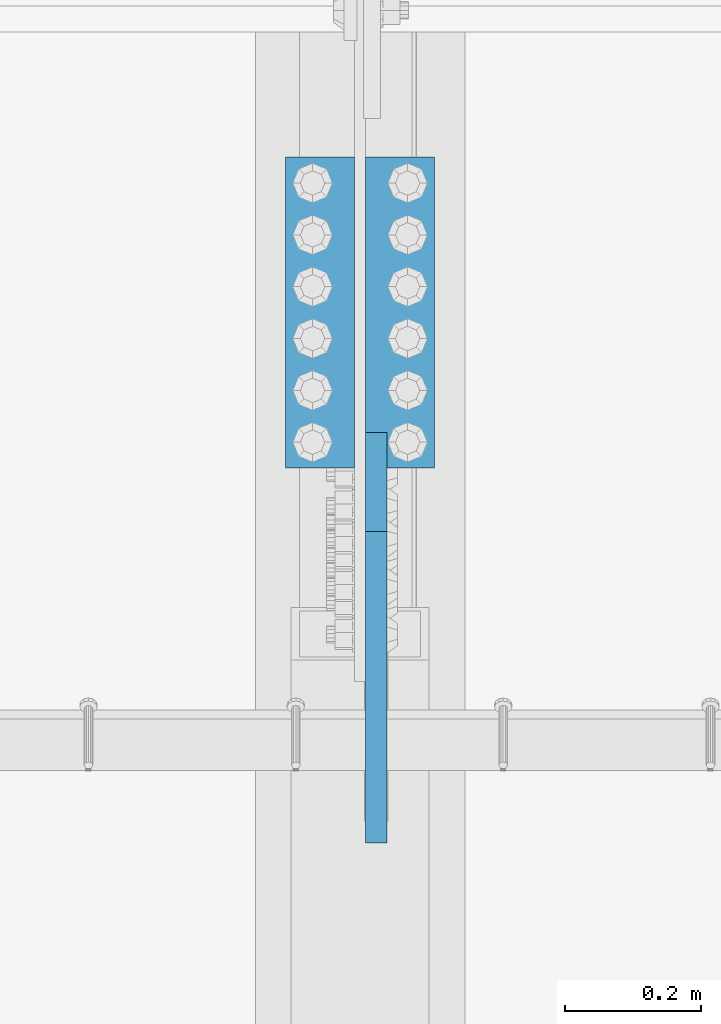
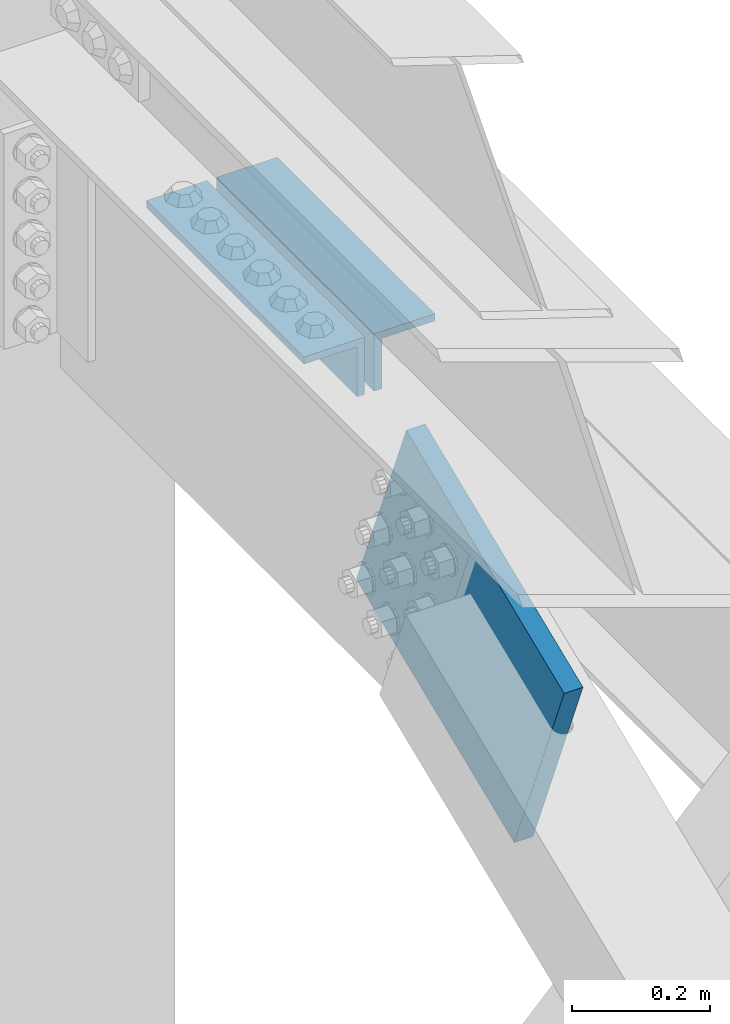
# One storey, part 2512 of 3843: 2 beams, 1 member, 2 elements without a shape of their own.
"""IFC2X3 building model written with IfcOpenShell, lengths in millimetres."""

import ifcopenshell
import ifcopenshell.guid

model = None  # the IFC model being written
_history = None  # IfcOwnerHistory: only IFC2X3 demands one
_inside = {}  # id of a spatial element -> (the spatial element, [elements in it])
_under = {}  # id of a project, library or spatial element -> (it, [spatial elements below it])
_declared = {}  # id of a project -> (the project, [libraries it declares])
_typed = {}  # id of a type object -> (the type object, [elements of that type])
_made_of = {}  # id of a material, layer set ... -> (it, [elements and type objects made of it])


def new_model(schema):
    """Start an empty IFC model of exactly this schema.

    Asked for "IFC4X3", IfcOpenShell would pick the latest addendum, in which some entities
    have other attributes; the version numbers below select the first issue.
    IFC2X3 requires an IfcOwnerHistory on every rooted entity: one is made here for all.
    """
    global model, _history
    if schema == "IFC4X3":
        model = ifcopenshell.file(schema_version=(4, 3, 0, 0))
    else:
        model = ifcopenshell.file(schema=schema)
    _inside.clear()
    _under.clear()
    _declared.clear()
    _typed.clear()
    _made_of.clear()
    _history = None
    if model.schema == "IFC2X3":
        org = make("IfcOrganization", Name="unknown")
        user = make(
            "IfcPersonAndOrganization",
            ThePerson=make("IfcPerson", FamilyName="unknown"),
            TheOrganization=org,
        )
        app = make(
            "IfcApplication",
            ApplicationDeveloper=org,
            Version="unknown",
            ApplicationFullName="unknown",
            ApplicationIdentifier="unknown",
        )
        _history = make(
            "IfcOwnerHistory",
            OwningUser=user,
            OwningApplication=app,
            ChangeAction="ADDED",
            CreationDate=0,
        )
    return model


def make(cls, **values):
    """One entity of the class cls with the attributes given. An attribute that is None is left unset."""
    return model.create_entity(
        cls, **{name: value for name, value in values.items() if value is not None}
    )


def rooted(cls, **values):
    """An entity with a GlobalId (a new one), such as an element, a storey or a relation."""
    return make(cls, GlobalId=ifcopenshell.guid.new(), OwnerHistory=_history, **values)


def si_unit(unit_type, name, prefix=None):
    """IfcSIUnit, for example si_unit("LENGTHUNIT", "METRE", prefix="MILLI")."""
    return make("IfcSIUnit", UnitType=unit_type, Prefix=prefix, Name=name)


def assignment(units):
    """IfcUnitAssignment: the units of a project."""
    return None if units is None else make("IfcUnitAssignment", Units=units)


def point(xyz):
    """IfcCartesianPoint."""
    return None if xyz is None else make("IfcCartesianPoint", Coordinates=xyz)


def direction(xyz):
    """IfcDirection."""
    return None if xyz is None else make("IfcDirection", DirectionRatios=xyz)


def frame(location, z_axis=None, x_axis=None):
    """IfcAxis2Placement3D, a coordinate frame: its origin and axes. An axis left out is left unset."""
    return make(
        "IfcAxis2Placement3D",
        Location=point(location),
        Axis=direction(z_axis),
        RefDirection=direction(x_axis),
    )


def origin_with_axes():
    """The frame at (0, 0, 0) with the z axis (0, 0, 1) and the x axis (1, 0, 0) written out."""
    return frame((0.0, 0.0, 0.0), z_axis=(0.0, 0.0, 1.0), x_axis=(1.0, 0.0, 0.0))


def place(relative_to, where):
    """IfcLocalPlacement: puts the frame where relative to a parent placement (None: the world)."""
    return make(
        "IfcLocalPlacement", PlacementRelTo=relative_to, RelativePlacement=where
    )


def context(
    kind, dimensions, precision=None, world=None, true_north=None, identifier=None
):
    """IfcGeometricRepresentationContext, for example the 3D "Model" context."""
    return make(
        "IfcGeometricRepresentationContext",
        ContextIdentifier=identifier,
        ContextType=kind,
        CoordinateSpaceDimension=dimensions,
        Precision=precision,
        WorldCoordinateSystem=world,
        TrueNorth=true_north,
    )


def subcontext(parent, identifier, kind, view, scale=None):
    """IfcGeometricRepresentationSubContext, for example "Body" below "Model"."""
    return make(
        "IfcGeometricRepresentationSubContext",
        ContextIdentifier=identifier,
        ContextType=kind,
        ParentContext=parent,
        TargetScale=scale,
        TargetView=view,
    )


def project(units=None, contexts=None):
    """IfcProject with its units and contexts."""
    return rooted(
        "IfcProject",
        Name="project",
        RepresentationContexts=contexts,
        UnitsInContext=assignment(units),
    )


def spatial(cls, under=None, at=None, **own):
    """A site, building, storey or space (cls), placed at a placement, below another one or the project."""
    s = rooted(cls, ObjectPlacement=at, **own)
    if under is not None:
        _under.setdefault(under.id(), (under, []))[1].append(s)
    return s


def faces_of(points, faces, orient=None, outer=None):
    """IfcFace entities. A face is a list of loops; a loop is a list of indices into points, from 0.

    orient and outer hold one flag for each loop. By default every Orientation is true, the
    first loop of a face is its IfcFaceOuterBound and the others are IfcFaceBound.
    """
    made = []
    for i, loops in enumerate(faces):
        bounds = []
        for j, loop in enumerate(loops):
            is_outer = j == 0 if outer is None else outer[i][j]
            bounds.append(
                make(
                    "IfcFaceOuterBound" if is_outer else "IfcFaceBound",
                    Bound=make("IfcPolyLoop", Polygon=[points[k] for k in loop]),
                    Orientation=True if orient is None else orient[i][j],
                )
            )
        made.append(make("IfcFace", Bounds=bounds))
    return made


def faceted_brep(points, faces, orient=None, outer=None, voids=None):
    """IfcFacetedBrep: a solid bounded by flat faces; with voids (closed shells), ...WithVoids."""
    shared = [point(p) for p in points]
    hull = make("IfcClosedShell", CfsFaces=faces_of(shared, faces, orient, outer))
    if voids is None:
        return make("IfcFacetedBrep", Outer=hull)
    return make(
        "IfcFacetedBrepWithVoids",
        Outer=hull,
        Voids=[
            make(cls, CfsFaces=faces_of(shared, fs, o, b)) for cls, fs, o, b in voids
        ],
    )


def shape(context_of_items, identifier, shape_type, items):
    """IfcShapeRepresentation: the items that make up one representation, for example the "Body"."""
    return make(
        "IfcShapeRepresentation",
        ContextOfItems=context_of_items,
        RepresentationIdentifier=identifier,
        RepresentationType=shape_type,
        Items=items,
    )


def material(Name=None, Category=None):
    """IfcMaterial."""
    return make("IfcMaterial", Name=Name, Category=Category)


def made_of(thing, what):
    """Note that an element or type object is made of a material, layer set ...; save() writes the relation."""
    if what is not None:
        _made_of.setdefault(what.id(), (what, []))[1].append(thing)
    return thing


def type_object(cls, material=None, **own):
    """A type object (cls), such as IfcWallType, which elements share."""
    return made_of(rooted(cls, **own), material)


def element(
    cls,
    number,
    at=None,
    inside=None,
    cuts=None,
    type_object=None,
    material=None,
    context=None,
    identifier="Body",
    shape_type=None,
    held_by="IfcProductDefinitionShape",
    body=None,
    shapes=None,
    **own,
):
    """One element of the class cls, such as IfcWall. Its Tag is "e" and its number.

    at: its placement. inside: the storey or other place that contains it. cuts: it is an
    opening in that element (IfcRelVoidsElement). A single representation is given by context,
    identifier, shape_type and body (its items); several are given by shapes. held_by: the class
    of the entity that holds the representations. save() writes the other relations.
    """
    e = rooted(cls, Tag="e%d" % number, ObjectPlacement=at, **own)
    if body is not None:
        shapes = [shape(context, identifier, shape_type, body)]
    if shapes is not None:
        e.Representation = make(held_by, Representations=shapes)
    if inside is not None:
        _inside.setdefault(inside.id(), (inside, []))[1].append(e)
    if cuts is not None:
        rooted(
            "IfcRelVoidsElement", RelatingBuildingElement=cuts, RelatedOpeningElement=e
        )
    if type_object is not None:
        _typed.setdefault(type_object.id(), (type_object, []))[1].append(e)
    return made_of(e, material)


def aggregate(whole, parts):
    """IfcRelAggregates: a whole, such as a stair, and the parts it consists of."""
    return rooted("IfcRelAggregates", RelatingObject=whole, RelatedObjects=parts)


def save(model, path):
    """Write the relations noted so far, then the file.

    IfcRelAggregates (storeys below a building ...), IfcRelContainedInSpatialStructure (elements
    in a storey), IfcRelDefinesByType, IfcRelAssociatesMaterial and IfcRelDeclares: one each for
    every whole, place, type object, material and project.
    """
    for whole, parts in _under.values():
        aggregate(whole, parts)
    for where, things in _inside.values():
        rooted(
            "IfcRelContainedInSpatialStructure",
            RelatedElements=things,
            RelatingStructure=where,
        )
    for kind, things in _typed.values():
        rooted("IfcRelDefinesByType", RelatedObjects=things, RelatingType=kind)
    for what, things in _made_of.values():
        rooted("IfcRelAssociatesMaterial", RelatedObjects=things, RelatingMaterial=what)
    for by, libraries in _declared.values():
        rooted("IfcRelDeclares", RelatingContext=by, RelatedDefinitions=libraries)
    model.write(path)


model = new_model("IFC2X3")

# Units and contexts
model_context = context("Model", 3, precision=1e-05, world=origin_with_axes())
body_context = subcontext(model_context, "Body", "Model", "MODEL_VIEW")
ifc_project = project(units=[si_unit("LENGTHUNIT", "METRE", prefix="MILLI"), si_unit("AREAUNIT", "SQUARE_METRE"), si_unit("VOLUMEUNIT", "CUBIC_METRE"), si_unit("MASSUNIT", "GRAM", prefix="KILO"), si_unit("TIMEUNIT", "SECOND"), si_unit("PLANEANGLEUNIT", "RADIAN"), si_unit("SOLIDANGLEUNIT", "STERADIAN"), si_unit("THERMODYNAMICTEMPERATUREUNIT", "DEGREE_CELSIUS"), si_unit("LUMINOUSINTENSITYUNIT", "LUMEN")], contexts=[model_context])

# Site, building, storey
site_placement = place(None, origin_with_axes())
site = spatial("IfcSite", under=ifc_project, at=site_placement, CompositionType="ELEMENT")
building_placement = place(site_placement, origin_with_axes())
building = spatial("IfcBuilding", under=site, at=building_placement, Name="Undefined", CompositionType="ELEMENT")
storey_placement = place(building_placement, origin_with_axes())
storey = spatial("IfcBuildingStorey", under=building, at=storey_placement, Name="Undefined", CompositionType="ELEMENT", Elevation=0.0)

# Assembly, beams
assembly_1_placement = place(storey_placement, origin_with_axes())
assembly_1 = element("IfcElementAssembly", 1, at=assembly_1_placement, inside=storey, Name="PLATE", AssemblyPlace="NOTDEFINED", PredefinedType="RIGID_FRAME")
ifc_material = material(Name="STEEL/A572-50")
beam_type = type_object("IfcBeamType", Name="L4X4X1/2", PredefinedType="NOTDEFINED")
beam_1_placement = place(assembly_1_placement, frame((55989.5375001665, 91611.4499999985, 45435.5159830581), z_axis=(0.0, 0.0, -1.0), x_axis=(0.0, -1.0, 0.0)))
beam_1 = element("IfcBeam", 2, at=beam_1_placement, type_object=beam_type, material=ifc_material, Name="ANGLE", ObjectType="L4X4X1/2", context=body_context, shape_type="Brep", body=[
    faceted_brep([(0.0, 50.8000000000029, -50.8000000000029), (0.0, 50.8000000000029, 50.8000000000029), (457.199999999997, 50.8000000000029, 50.8000000000029), (457.199999999997, 50.8000000000029, -50.8000000000029), (0.0, 38.0999999999985, 50.8000000000029), (457.199999999997, 38.0999999999985, 50.8000000000029), (0.0, 38.0999999999985, -38.0999999999985), (457.199999999997, 38.0999999999985, -38.0999999999985), (0.0, -50.8000000000029, -38.1000000000058), (457.199999999997, -50.8000000000029, -38.0999999999985), (0.0, -50.8000000000029, -50.8000000000029), (457.199999999997, -50.8000000000029, -50.8000000000029)], [[[0, 1, 2, 3]], [[1, 4, 5, 2]], [[4, 6, 7, 5]], [[6, 8, 9, 7]], [[8, 10, 11, 9]], [[10, 0, 3, 11]], [[5, 7, 9, 11, 3, 2]], [[10, 8, 6, 4, 1, 0]]]),
])
beam_2_placement = place(assembly_1_placement, frame((55872.0625001565, 91154.2499999959, 45435.5159830781), z_axis=(0.0, 0.0, -1.0), x_axis=(0.0, 1.0, 0.0)))
beam_2 = element("IfcBeam", 3, at=beam_2_placement, type_object=beam_type, material=ifc_material, Name="ANGLE", ObjectType="L4X4X1/2", context=body_context, shape_type="Brep", body=[
    faceted_brep([(0.0, 50.8000000000029, -50.8000000000029), (0.0, 50.8000000000029, 50.8000000000029), (457.199999999997, 50.8000000000029, 50.8000000000029), (457.199999999997, 50.8000000000029, -50.8000000000029), (0.0, 38.0999999999985, 50.8000000000029), (457.199999999997, 38.0999999999985, 50.8000000000029), (0.0, 38.0999999999985, -38.0999999999985), (457.199999999997, 38.0999999999985, -38.0999999999985), (0.0, -50.8000000000029, -38.1000000000058), (457.199999999997, -50.8000000000029, -38.0999999999985), (0.0, -50.8000000000029, -50.8000000000029), (457.199999999997, -50.8000000000029, -50.8000000000029)], [[[0, 1, 2, 3]], [[1, 4, 5, 2]], [[4, 6, 7, 5]], [[6, 8, 9, 7]], [[8, 10, 11, 9]], [[10, 0, 3, 11]], [[5, 7, 9, 11, 3, 2]], [[10, 8, 6, 4, 1, 0]]]),
])
aggregate(assembly_1, [beam_1, beam_2])

# Assembly, member
assembly_2_placement = place(storey_placement, origin_with_axes())
assembly_2 = element("IfcElementAssembly", 4, at=assembly_2_placement, inside=storey, AssemblyPlace="NOTDEFINED", PredefinedType="RIGID_FRAME")
member_type = type_object("IfcMemberType", PredefinedType="NOTDEFINED")
member_placement = place(assembly_2_placement, frame((55954.6125, 91133.9156240024, 45195.8327879808), z_axis=(0.0, -0.380341379181817, 0.924846168442122), x_axis=(0.0, -0.924846168442123, -0.380341379181814)))
member = element("IfcMember", 5, at=member_placement, type_object=member_type, material=ifc_material, Name="PLATE", context=body_context, shape_type="Brep", body=[
    faceted_brep([(3.56521923094988e-10, 15.875, -190.500000000146), (-3.61978891305625e-10, 15.875, 190.500000000153), (495.299999995012, 15.875, 190.500000001084), (495.299999995726, 15.875, -190.499999999221), (-3.61978891305625e-10, -15.875, 190.500000000153), (495.299999995012, -15.875, 190.500000001084), (3.56521923094988e-10, -15.875, -190.500000000146), (495.299999995726, -15.875, -190.499999999221)], [[[0, 1, 2, 3]], [[1, 4, 5, 2]], [[4, 6, 7, 5]], [[6, 0, 3, 7]], [[5, 7, 3, 2]], [[6, 4, 1, 0]]]),
])
aggregate(assembly_2, [member])

save(model, "model.ifc")
